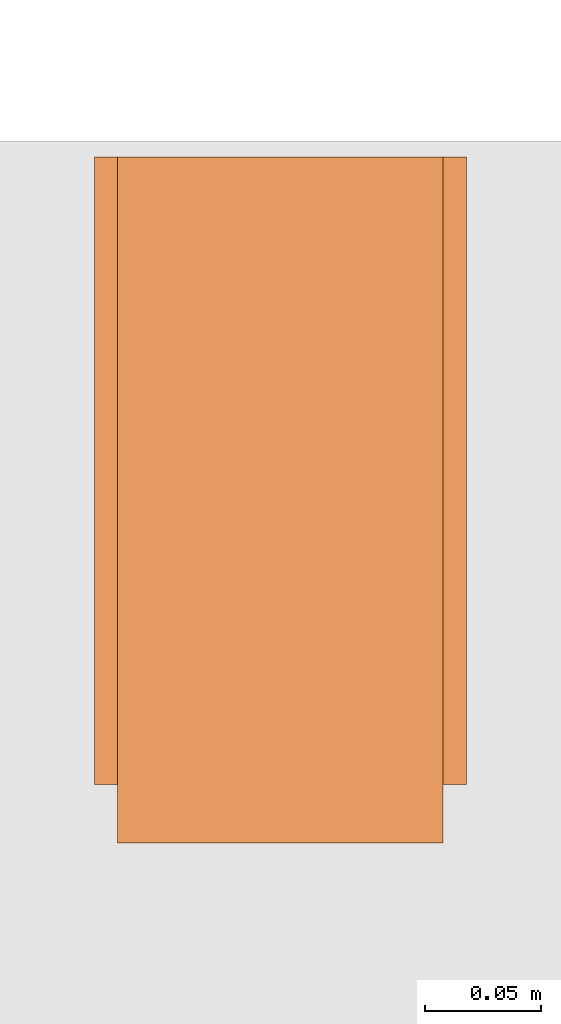
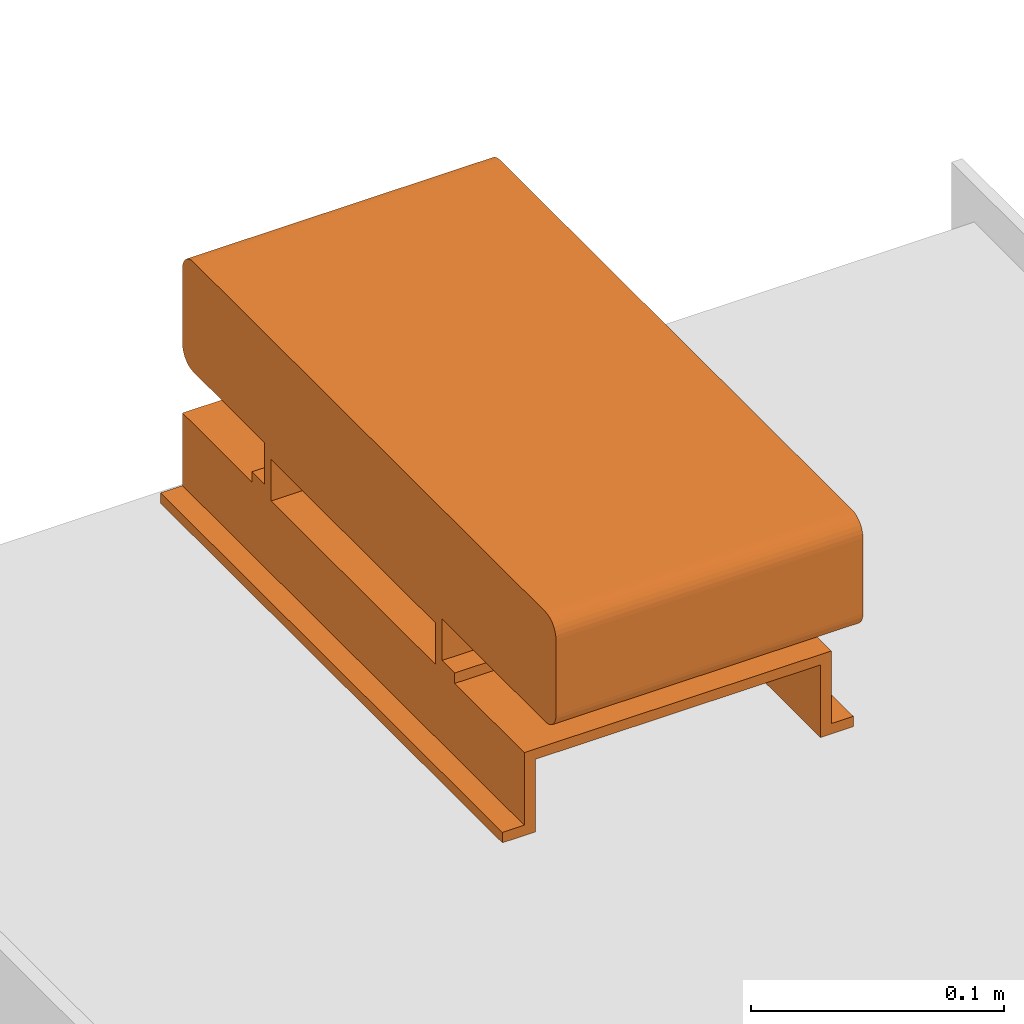
# One storey, part 32 of 32: 1 proxy.
"""IFC2X3 building model written with IfcOpenShell, lengths in millimetres."""

import ifcopenshell
import ifcopenshell.guid

model = None  # the IFC model being written
_history = None  # IfcOwnerHistory: only IFC2X3 demands one
_inside = {}  # id of a spatial element -> (the spatial element, [elements in it])
_under = {}  # id of a project, library or spatial element -> (it, [spatial elements below it])
_declared = {}  # id of a project -> (the project, [libraries it declares])
_typed = {}  # id of a type object -> (the type object, [elements of that type])
_made_of = {}  # id of a material, layer set ... -> (it, [elements and type objects made of it])


def new_model(schema):
    """Start an empty IFC model of exactly this schema.

    Asked for "IFC4X3", IfcOpenShell would pick the latest addendum, in which some entities
    have other attributes; the version numbers below select the first issue.
    IFC2X3 requires an IfcOwnerHistory on every rooted entity: one is made here for all.
    """
    global model, _history
    if schema == "IFC4X3":
        model = ifcopenshell.file(schema_version=(4, 3, 0, 0))
    else:
        model = ifcopenshell.file(schema=schema)
    _inside.clear()
    _under.clear()
    _declared.clear()
    _typed.clear()
    _made_of.clear()
    _history = None
    if model.schema == "IFC2X3":
        org = make("IfcOrganization", Name="unknown")
        user = make(
            "IfcPersonAndOrganization",
            ThePerson=make("IfcPerson", FamilyName="unknown"),
            TheOrganization=org,
        )
        app = make(
            "IfcApplication",
            ApplicationDeveloper=org,
            Version="unknown",
            ApplicationFullName="unknown",
            ApplicationIdentifier="unknown",
        )
        _history = make(
            "IfcOwnerHistory",
            OwningUser=user,
            OwningApplication=app,
            ChangeAction="ADDED",
            CreationDate=0,
        )
    return model


def make(cls, **values):
    """One entity of the class cls with the attributes given. An attribute that is None is left unset."""
    return model.create_entity(
        cls, **{name: value for name, value in values.items() if value is not None}
    )


def entity(cls, *values):
    """Any entity or typed value of the class cls, its attributes in the order of the schema. None: left unset."""
    e = model.create_entity(cls)
    for i, value in enumerate(values):
        if value is not None:
            e[i] = value
    return e


def rooted(cls, **values):
    """An entity with a GlobalId (a new one), such as an element, a storey or a relation."""
    return make(cls, GlobalId=ifcopenshell.guid.new(), OwnerHistory=_history, **values)


def si_unit(unit_type, name, prefix=None):
    """IfcSIUnit, for example si_unit("LENGTHUNIT", "METRE", prefix="MILLI")."""
    return make("IfcSIUnit", UnitType=unit_type, Prefix=prefix, Name=name)


def converted_unit(unit_type, name, factor, base, dimensions=None, offset=None):
    """IfcConversionBasedUnit, such as the inch: factor (a typed value) times the base unit."""
    return make(
        "IfcConversionBasedUnit"
        if offset is None
        else "IfcConversionBasedUnitWithOffset",
        ConversionOffset=offset,
        Dimensions=None
        if dimensions is None
        else entity("IfcDimensionalExponents", *dimensions),
        UnitType=unit_type,
        Name=name,
        ConversionFactor=make(
            "IfcMeasureWithUnit", ValueComponent=factor, UnitComponent=base
        ),
    )


def derived_unit(unit_type, elements):
    """IfcDerivedUnit: a product of units, each with its exponent."""
    return make(
        "IfcDerivedUnit",
        Elements=[
            make("IfcDerivedUnitElement", Unit=unit, Exponent=power)
            for unit, power in elements
        ],
        UnitType=unit_type,
    )


def assignment(units):
    """IfcUnitAssignment: the units of a project."""
    return None if units is None else make("IfcUnitAssignment", Units=units)


def point(xyz):
    """IfcCartesianPoint."""
    return None if xyz is None else make("IfcCartesianPoint", Coordinates=xyz)


def direction(xyz):
    """IfcDirection."""
    return None if xyz is None else make("IfcDirection", DirectionRatios=xyz)


def frame(location, z_axis=None, x_axis=None):
    """IfcAxis2Placement3D, a coordinate frame: its origin and axes. An axis left out is left unset."""
    return make(
        "IfcAxis2Placement3D",
        Location=point(location),
        Axis=direction(z_axis),
        RefDirection=direction(x_axis),
    )


def frame_2d(location, x_axis=None):
    """IfcAxis2Placement2D, a coordinate frame in the plane: its origin and x axis."""
    return make(
        "IfcAxis2Placement2D", Location=point(location), RefDirection=direction(x_axis)
    )


def origin():
    """The frame at (0, 0, 0) with its axes left unset."""
    return frame((0.0, 0.0, 0.0))


def place(relative_to, where):
    """IfcLocalPlacement: puts the frame where relative to a parent placement (None: the world)."""
    return make(
        "IfcLocalPlacement", PlacementRelTo=relative_to, RelativePlacement=where
    )


def context(
    kind, dimensions, precision=None, world=None, true_north=None, identifier=None
):
    """IfcGeometricRepresentationContext, for example the 3D "Model" context."""
    return make(
        "IfcGeometricRepresentationContext",
        ContextIdentifier=identifier,
        ContextType=kind,
        CoordinateSpaceDimension=dimensions,
        Precision=precision,
        WorldCoordinateSystem=world,
        TrueNorth=true_north,
    )


def subcontext(parent, identifier, kind, view, scale=None):
    """IfcGeometricRepresentationSubContext, for example "Body" below "Model"."""
    return make(
        "IfcGeometricRepresentationSubContext",
        ContextIdentifier=identifier,
        ContextType=kind,
        ParentContext=parent,
        TargetScale=scale,
        TargetView=view,
    )


def project(units=None, contexts=None):
    """IfcProject with its units and contexts."""
    return rooted(
        "IfcProject",
        Name="project",
        RepresentationContexts=contexts,
        UnitsInContext=assignment(units),
    )


def spatial(cls, under=None, at=None, **own):
    """A site, building, storey or space (cls), placed at a placement, below another one or the project."""
    s = rooted(cls, ObjectPlacement=at, **own)
    if under is not None:
        _under.setdefault(under.id(), (under, []))[1].append(s)
    return s


def polyline(points):
    """IfcPolyline through the points."""
    return make("IfcPolyline", Points=[point(p) for p in points])


def circle_curve(where, radius):
    """IfcCircle in the frame where."""
    return make("IfcCircle", Position=where, Radius=radius)


def parameter(value):
    """IfcParameterValue: where a trimmed curve begins or ends, as a parameter of its basis curve."""
    return model.create_entity("IfcParameterValue", value)


def trimmed(basis, trim1, trim2, sense, master):
    """IfcTrimmedCurve: the piece of a basis curve between two trims."""
    return make(
        "IfcTrimmedCurve",
        BasisCurve=basis,
        Trim1=trim1,
        Trim2=trim2,
        SenseAgreement=sense,
        MasterRepresentation=master,
    )


def segment(curve, same_sense, transition):
    """IfcCompositeCurveSegment."""
    return make(
        "IfcCompositeCurveSegment",
        Transition=transition,
        SameSense=same_sense,
        ParentCurve=curve,
    )


def composite_curve(segments, self_intersect=None):
    """IfcCompositeCurve: segments joined end to end."""
    return make("IfcCompositeCurve", Segments=segments, SelfIntersect=self_intersect)


def outline(outer, holes=None, kind="AREA"):
    """IfcArbitraryClosedProfileDef: a profile drawn as a closed curve; with holes, ...WithVoids."""
    if holes is None:
        return make("IfcArbitraryClosedProfileDef", ProfileType=kind, OuterCurve=outer)
    return make(
        "IfcArbitraryProfileDefWithVoids",
        ProfileType=kind,
        OuterCurve=outer,
        InnerCurves=holes,
    )


def extrude(swept, where, along, depth):
    """IfcExtrudedAreaSolid: the profile swept, set in the frame where, extruded along a direction by depth."""
    return make(
        "IfcExtrudedAreaSolid",
        SweptArea=swept,
        Position=where,
        ExtrudedDirection=direction(along),
        Depth=depth,
    )


def shape(context_of_items, identifier, shape_type, items):
    """IfcShapeRepresentation: the items that make up one representation, for example the "Body"."""
    return make(
        "IfcShapeRepresentation",
        ContextOfItems=context_of_items,
        RepresentationIdentifier=identifier,
        RepresentationType=shape_type,
        Items=items,
    )


def source(mapping_origin, context_of_items, identifier, shape_type, items):
    """IfcRepresentationMap: a shape defined once, which mapped items show again and again."""
    return make(
        "IfcRepresentationMap",
        MappingOrigin=mapping_origin,
        MappedRepresentation=shape(context_of_items, identifier, shape_type, items),
    )


def transform(
    local_origin,
    x_axis=None,
    y_axis=None,
    z_axis=None,
    scale=None,
    scale2=None,
    scale3=None,
    uniform=True,
):
    """IfcCartesianTransformationOperator3D, or its non-uniform kind. x_axis, y_axis, z_axis: its Axis1, 2, 3."""
    if uniform:
        return make(
            "IfcCartesianTransformationOperator3D",
            Axis1=direction(x_axis),
            Axis2=direction(y_axis),
            LocalOrigin=point(local_origin),
            Scale=scale,
            Axis3=direction(z_axis),
        )
    return make(
        "IfcCartesianTransformationOperator3DnonUniform",
        Axis1=direction(x_axis),
        Axis2=direction(y_axis),
        LocalOrigin=point(local_origin),
        Scale=scale,
        Axis3=direction(z_axis),
        Scale2=scale2,
        Scale3=scale3,
    )


def mapped(mapping_source, mapping_target):
    """IfcMappedItem: shows the shape of a source again, moved by a transform."""
    return make(
        "IfcMappedItem", MappingSource=mapping_source, MappingTarget=mapping_target
    )


def material(Name=None, Category=None):
    """IfcMaterial."""
    return make("IfcMaterial", Name=Name, Category=Category)


def material_list(materials):
    """IfcMaterialList."""
    return make("IfcMaterialList", Materials=materials)


def made_of(thing, what):
    """Note that an element or type object is made of a material, layer set ...; save() writes the relation."""
    if what is not None:
        _made_of.setdefault(what.id(), (what, []))[1].append(thing)
    return thing


def type_object(cls, material=None, **own):
    """A type object (cls), such as IfcWallType, which elements share."""
    return made_of(rooted(cls, **own), material)


def type_shapes(of_type, sources):
    """Give a type object the sources (RepresentationMaps) that its elements show as mapped items."""
    of_type.RepresentationMaps = sources


def element(
    cls,
    number,
    at=None,
    inside=None,
    cuts=None,
    type_object=None,
    material=None,
    context=None,
    identifier="Body",
    shape_type=None,
    held_by="IfcProductDefinitionShape",
    body=None,
    shapes=None,
    **own,
):
    """One element of the class cls, such as IfcWall. Its Tag is "e" and its number.

    at: its placement. inside: the storey or other place that contains it. cuts: it is an
    opening in that element (IfcRelVoidsElement). A single representation is given by context,
    identifier, shape_type and body (its items); several are given by shapes. held_by: the class
    of the entity that holds the representations. save() writes the other relations.
    """
    e = rooted(cls, Tag="e%d" % number, ObjectPlacement=at, **own)
    if body is not None:
        shapes = [shape(context, identifier, shape_type, body)]
    if shapes is not None:
        e.Representation = make(held_by, Representations=shapes)
    if inside is not None:
        _inside.setdefault(inside.id(), (inside, []))[1].append(e)
    if cuts is not None:
        rooted(
            "IfcRelVoidsElement", RelatingBuildingElement=cuts, RelatedOpeningElement=e
        )
    if type_object is not None:
        _typed.setdefault(type_object.id(), (type_object, []))[1].append(e)
    return made_of(e, material)


def aggregate(whole, parts):
    """IfcRelAggregates: a whole, such as a stair, and the parts it consists of."""
    return rooted("IfcRelAggregates", RelatingObject=whole, RelatedObjects=parts)


def save(model, path):
    """Write the relations noted so far, then the file.

    IfcRelAggregates (storeys below a building ...), IfcRelContainedInSpatialStructure (elements
    in a storey), IfcRelDefinesByType, IfcRelAssociatesMaterial and IfcRelDeclares: one each for
    every whole, place, type object, material and project.
    """
    for whole, parts in _under.values():
        aggregate(whole, parts)
    for where, things in _inside.values():
        rooted(
            "IfcRelContainedInSpatialStructure",
            RelatedElements=things,
            RelatingStructure=where,
        )
    for kind, things in _typed.values():
        rooted("IfcRelDefinesByType", RelatedObjects=things, RelatingType=kind)
    for what, things in _made_of.values():
        rooted("IfcRelAssociatesMaterial", RelatedObjects=things, RelatingMaterial=what)
    for by, libraries in _declared.values():
        rooted("IfcRelDeclares", RelatingContext=by, RelatedDefinitions=libraries)
    model.write(path)


model = new_model("IFC2X3")

# Units and contexts
model_context = context("Model", 3, precision=0.01, world=origin(), true_north=direction((6.12303176911189e-17, 1.0)))
body_context = subcontext(model_context, "Body", "Model", "MODEL_VIEW")
ifc_project = project(units=[si_unit("LENGTHUNIT", "METRE", prefix="MILLI"), si_unit("AREAUNIT", "SQUARE_METRE"), si_unit("VOLUMEUNIT", "CUBIC_METRE"), converted_unit("PLANEANGLEUNIT", "DEGREE", entity("IfcRatioMeasure", 0.0174532925199433), si_unit("PLANEANGLEUNIT", "RADIAN"), dimensions=[0, 0, 0, 0, 0, 0, 0]), si_unit("MASSUNIT", "GRAM", prefix="KILO"), derived_unit("MASSDENSITYUNIT", [(si_unit("MASSUNIT", "GRAM", prefix="KILO"), 1), (si_unit("LENGTHUNIT", "METRE"), -3)]), derived_unit("MOMENTOFINERTIAUNIT", [(si_unit("LENGTHUNIT", "METRE"), 4)]), si_unit("TIMEUNIT", "SECOND"), si_unit("FREQUENCYUNIT", "HERTZ"), si_unit("THERMODYNAMICTEMPERATUREUNIT", "DEGREE_CELSIUS"), derived_unit("THERMALTRANSMITTANCEUNIT", [(si_unit("MASSUNIT", "GRAM", prefix="KILO"), 1), (si_unit("THERMODYNAMICTEMPERATUREUNIT", "KELVIN"), -1), (si_unit("TIMEUNIT", "SECOND"), -3)]), derived_unit("VOLUMETRICFLOWRATEUNIT", [(si_unit("LENGTHUNIT", "METRE"), 3), (si_unit("TIMEUNIT", "SECOND"), -1)]), derived_unit("MASSFLOWRATEUNIT", [(si_unit("MASSUNIT", "GRAM", prefix="KILO"), 1), (si_unit("TIMEUNIT", "SECOND"), -1)]), derived_unit("ROTATIONALFREQUENCYUNIT", [(si_unit("TIMEUNIT", "SECOND"), -1)]), si_unit("ELECTRICCURRENTUNIT", "AMPERE"), si_unit("ELECTRICVOLTAGEUNIT", "VOLT"), si_unit("POWERUNIT", "WATT"), si_unit("FORCEUNIT", "NEWTON", prefix="KILO"), si_unit("ILLUMINANCEUNIT", "LUX"), si_unit("LUMINOUSFLUXUNIT", "LUMEN"), si_unit("LUMINOUSINTENSITYUNIT", "CANDELA"), derived_unit("USERDEFINED", [(si_unit("MASSUNIT", "GRAM", prefix="KILO"), -1), (si_unit("LENGTHUNIT", "METRE"), -2), (si_unit("TIMEUNIT", "SECOND"), 3), (si_unit("LUMINOUSFLUXUNIT", "LUMEN"), 1)]), derived_unit("LINEARVELOCITYUNIT", [(si_unit("LENGTHUNIT", "METRE"), 1), (si_unit("TIMEUNIT", "SECOND"), -1)]), si_unit("PRESSUREUNIT", "PASCAL"), derived_unit("USERDEFINED", [(si_unit("LENGTHUNIT", "METRE"), -2), (si_unit("MASSUNIT", "GRAM", prefix="KILO"), 1), (si_unit("TIMEUNIT", "SECOND"), -2)]), derived_unit("LINEARFORCEUNIT", [(si_unit("MASSUNIT", "GRAM", prefix="KILO"), 1), (si_unit("LENGTHUNIT", "METRE"), 1), (si_unit("TIMEUNIT", "SECOND"), -2), (si_unit("LENGTHUNIT", "METRE"), -1)]), derived_unit("PLANARFORCEUNIT", [(si_unit("MASSUNIT", "GRAM", prefix="KILO"), 1), (si_unit("LENGTHUNIT", "METRE"), 1), (si_unit("TIMEUNIT", "SECOND"), -2), (si_unit("LENGTHUNIT", "METRE"), -2)])], contexts=[model_context])

# Site, building, storey
site_placement = place(None, origin())
site = spatial("IfcSite", under=ifc_project, at=site_placement, CompositionType="ELEMENT")
building_placement = place(site_placement, origin())
building = spatial("IfcBuilding", under=site, at=building_placement, CompositionType="ELEMENT")
storey_placement = place(building_placement, frame((0.0, 0.0, 8100.0)))
storey = spatial("IfcBuildingStorey", under=building, at=storey_placement, CompositionType="ELEMENT", Elevation=8100.0)

# Proxy
ifc_material_1 = material()
ifc_material_2 = material()
ifc_material_list_1 = material_list([ifc_material_1, ifc_material_2])
ifc_material_list_2 = material_list([ifc_material_1, ifc_material_1, ifc_material_2])
building_element_proxy_type = type_object("IfcBuildingElementProxyType", PredefinedType="NOTDEFINED", material=ifc_material_list_2)
shared_shape = source(origin(), body_context, "Body", "SweptSolid", [
    extrude(outline(composite_curve([segment(polyline([(-18.16, -147.54), (18.05, -147.54)]), True, "CONTINUOUS"), segment(trimmed(circle_curve(frame_2d((18.05, -139.09), x_axis=(0.0, -1.0)), 8.44431603721898), [parameter(1.01777749806833e-13)], [parameter(90.0)], True, "PARAMETER"), True, "CONTINUOUS"), segment(polyline([(26.49, -139.09), (26.49, 139.31)]), True, "CONTINUOUS"), segment(trimmed(circle_curve(frame_2d((18.33, 139.31), x_axis=(0.0, -1.0)), 8.15582249386043), [parameter(90.0)], [parameter(180.0)], True, "PARAMETER"), True, "CONTINUOUS"), segment(polyline([(18.33, 147.46), (-18.18, 147.46)]), True, "CONTINUOUS"), segment(trimmed(circle_curve(frame_2d((-18.18, 139.13), x_axis=(0.0, -1.0)), 8.33189596389998), [parameter(180.0)], [parameter(270.0)], True, "PARAMETER"), True, "CONTINUOUS"), segment(polyline([(-26.51, 139.13), (-26.51, -139.19)]), True, "CONTINUOUS"), segment(trimmed(circle_curve(frame_2d((-18.16, -139.19), x_axis=(0.0, -1.0)), 8.35260143157827), [parameter(270.0)], [parameter(4.57999874130747e-13)], True, "PARAMETER"), True, "CONTINUOUS")], self_intersect=False)), frame((-70.0, 12.54, 91.49), z_axis=(1.0, 0.0, 0.0), x_axis=(0.0, 0.0, -1.0)), (0.0, 0.0, 1.0), 139.999999999992),
    extrude(outline(polyline([(-9.17, -80.0), (-4.17, -80.0), (-4.17, -70.0), (15.83, -70.0), (15.83, 70.0), (-4.17, 70.0), (-4.17, 80.0), (-9.17, 80.0), (-9.17, 65.0), (10.83, 65.0), (10.83, -65.0), (-9.17, -65.0), (-9.17, -80.0)])), frame((-70.0, 0.0, 49.17), z_axis=(1.0, 0.0, 0.0), x_axis=(0.0, 0.0, 1.0)), (0.0, 0.0, 1.0), 139.999999999992),
    extrude(outline(polyline([(-14.17, -80.0), (-9.17, -80.0), (-9.17, -70.0), (25.83, -70.0), (25.83, 70.0), (-9.17, 70.0), (-9.17, 80.0), (-14.17, 80.0), (-14.17, 65.0), (20.83, 65.0), (20.83, -65.0), (-14.17, -65.0), (-14.17, -80.0)])), frame((0.0, -135.0, 14.17), z_axis=(0.0, 1.0, 0.0), x_axis=(0.0, 0.0, 1.0)), (0.0, 0.0, 1.0), 270.0),
])
type_shapes(building_element_proxy_type, [shared_shape])
proxy_placement = place(storey_placement, frame((29923.31, 11700.16, 262.0), z_axis=(0.0, 0.0, 1.0), x_axis=(-1.0, 0.0, 0.0)))
element("IfcBuildingElementProxy", 1, at=proxy_placement, inside=storey, type_object=building_element_proxy_type, material=ifc_material_list_1, context=body_context, shape_type="MappedRepresentation", body=[
    mapped(shared_shape, transform((0.0, 0.0, 0.0), scale=1.0)),
])

save(model, "model.ifc")
